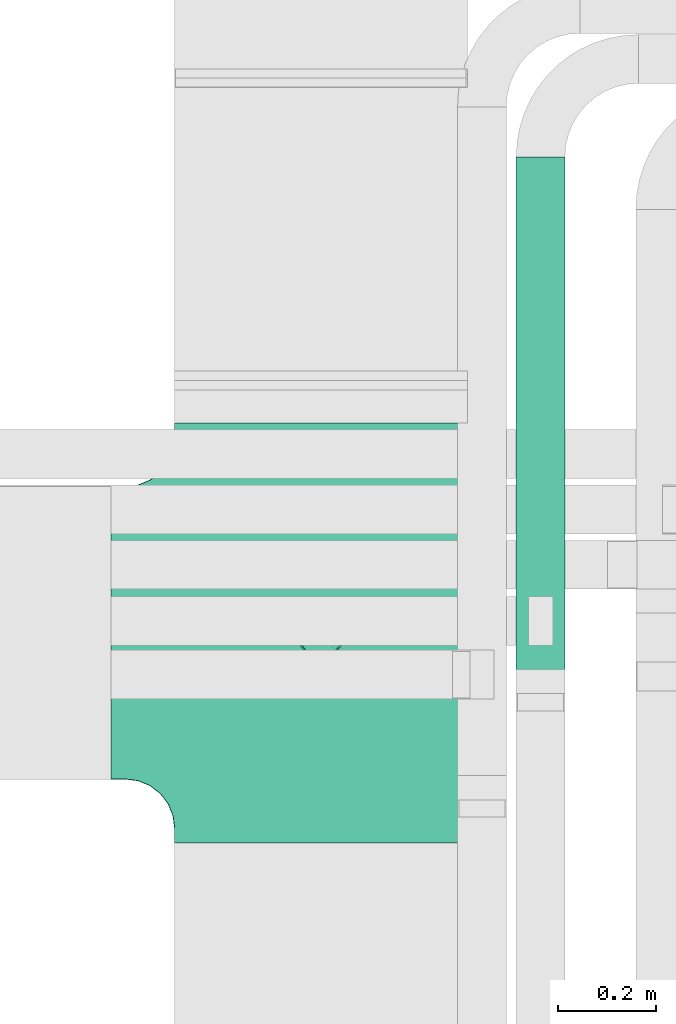
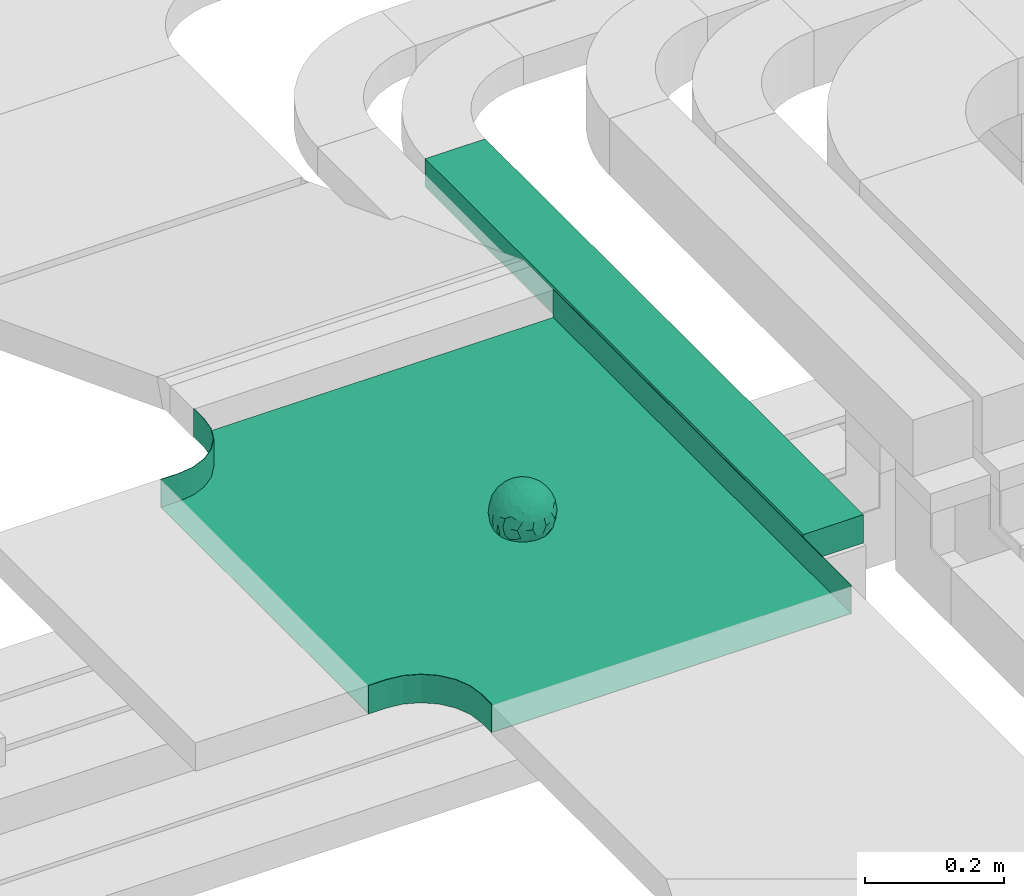
# One storey, part 2 of 38: 1 flow fitting, 1 flow segment.
"""IFC2X3 building model written with IfcOpenShell, lengths in millimetres."""

from ifc_helpers import new_model, entity, si_unit, converted_unit, derived_unit, direction, frame, origin, origin_2d_with_axis, place, context, subcontext, project, spatial, rectangle, extrude, faceted_brep, source, transform, mapped, material, material_list, type_object, type_shapes, element, save


model = new_model("IFC2X3")

# Units and contexts
model_context = context("Model", 3, precision=0.01, world=origin(), true_north=direction((6.12303176911189e-17, 1.0)))
body_context = subcontext(model_context, "Body", "Model", "MODEL_VIEW")
ifc_project = project(units=[si_unit("LENGTHUNIT", "METRE", prefix="MILLI"), si_unit("AREAUNIT", "SQUARE_METRE"), si_unit("VOLUMEUNIT", "CUBIC_METRE"), converted_unit("PLANEANGLEUNIT", "DEGREE", entity("IfcRatioMeasure", 0.0174532925199433), si_unit("PLANEANGLEUNIT", "RADIAN"), dimensions=[0, 0, 0, 0, 0, 0, 0]), si_unit("MASSUNIT", "GRAM", prefix="KILO"), derived_unit("MASSDENSITYUNIT", [(si_unit("MASSUNIT", "GRAM", prefix="KILO"), 1), (si_unit("LENGTHUNIT", "METRE"), -3)]), derived_unit("MOMENTOFINERTIAUNIT", [(si_unit("LENGTHUNIT", "METRE"), 4)]), si_unit("TIMEUNIT", "SECOND"), si_unit("FREQUENCYUNIT", "HERTZ"), si_unit("THERMODYNAMICTEMPERATUREUNIT", "DEGREE_CELSIUS"), derived_unit("THERMALTRANSMITTANCEUNIT", [(si_unit("MASSUNIT", "GRAM", prefix="KILO"), 1), (si_unit("THERMODYNAMICTEMPERATUREUNIT", "KELVIN"), -1), (si_unit("TIMEUNIT", "SECOND"), -3)]), derived_unit("VOLUMETRICFLOWRATEUNIT", [(si_unit("LENGTHUNIT", "METRE"), 3), (si_unit("TIMEUNIT", "SECOND"), -1)]), derived_unit("MASSFLOWRATEUNIT", [(si_unit("MASSUNIT", "GRAM", prefix="KILO"), 1), (si_unit("TIMEUNIT", "SECOND"), -1)]), derived_unit("ROTATIONALFREQUENCYUNIT", [(si_unit("TIMEUNIT", "SECOND"), -1)]), si_unit("ELECTRICCURRENTUNIT", "AMPERE"), si_unit("ELECTRICVOLTAGEUNIT", "VOLT"), si_unit("POWERUNIT", "WATT"), si_unit("FORCEUNIT", "NEWTON", prefix="KILO"), si_unit("ILLUMINANCEUNIT", "LUX"), si_unit("LUMINOUSFLUXUNIT", "LUMEN"), si_unit("LUMINOUSINTENSITYUNIT", "CANDELA"), derived_unit("USERDEFINED", [(si_unit("MASSUNIT", "GRAM", prefix="KILO"), -1), (si_unit("LENGTHUNIT", "METRE"), -2), (si_unit("TIMEUNIT", "SECOND"), 3), (si_unit("LUMINOUSFLUXUNIT", "LUMEN"), 1)]), derived_unit("LINEARVELOCITYUNIT", [(si_unit("LENGTHUNIT", "METRE"), 1), (si_unit("TIMEUNIT", "SECOND"), -1)]), si_unit("PRESSUREUNIT", "PASCAL"), derived_unit("USERDEFINED", [(si_unit("LENGTHUNIT", "METRE"), -2), (si_unit("MASSUNIT", "GRAM", prefix="KILO"), 1), (si_unit("TIMEUNIT", "SECOND"), -2)]), derived_unit("LINEARFORCEUNIT", [(si_unit("MASSUNIT", "GRAM", prefix="KILO"), 1), (si_unit("LENGTHUNIT", "METRE"), 1), (si_unit("TIMEUNIT", "SECOND"), -2), (si_unit("LENGTHUNIT", "METRE"), -1)]), derived_unit("PLANARFORCEUNIT", [(si_unit("MASSUNIT", "GRAM", prefix="KILO"), 1), (si_unit("LENGTHUNIT", "METRE"), 1), (si_unit("TIMEUNIT", "SECOND"), -2), (si_unit("LENGTHUNIT", "METRE"), -2)])], contexts=[model_context])

# Site, building, storey
site_placement = place(None, frame((0.0, -0.00077364408347762, 0.0)))
site = spatial("IfcSite", under=ifc_project, at=site_placement, CompositionType="ELEMENT")
building_placement = place(site_placement, origin())
building = spatial("IfcBuilding", under=site, at=building_placement, CompositionType="ELEMENT")
storey_placement = place(building_placement, frame((0.0, 0.0, 4200.0)))
storey = spatial("IfcBuildingStorey", under=building, at=storey_placement, CompositionType="ELEMENT", Elevation=4200.0)

# Flow segment
cable_carrier_segment_type = type_object("IfcCableCarrierSegmentType", PredefinedType="CABLETRAYSEGMENT")
flow_segment_placement = place(storey_placement, frame((10903.5911506353, 10608.7857236441, 2975.0)))
element("IfcFlowSegment", 1, at=flow_segment_placement, inside=storey, type_object=cable_carrier_segment_type, context=body_context, shape_type="SweptSolid", body=[
    extrude(rectangle(XDim=1091.74419399839, YDim=99.9999999999989, at=origin_2d_with_axis()), frame((50.0, 545.872096999197, 0.0), z_axis=(0.0, 0.0, 1.0), x_axis=(0.0, -1.0, 0.0)), (0.0, 0.0, 1.0), 49.9999999999995),
])

# Flow fitting
ifc_material_1 = material()
ifc_material_2 = material()
ifc_material_list = material_list([ifc_material_1, ifc_material_2])
cable_carrier_fitting_type = type_object("IfcCableCarrierFittingType", PredefinedType="NOTDEFINED", material=ifc_material_1)
shared_shape = source(origin(), body_context, "Body", "Brep", [
    faceted_brep([(43.65414201495, -13.6159823941412, -20.221792907194), (44.7734537304832, 0.0, -22.2561865791168), (48.2627667869764, -5.5982238187369, -11.8053052540677), (16.6591030416451, 5.32882774998004, -46.8409850521773), (11.5556000970565, -8.32997143460759, -47.9278591457525), (2.01883462715812, 2.6979389970297, -49.8863250993269), (-7.81264210311725, -35.946586740035, -33.8645171988286), (-17.2052206683237, -38.2719861359275, -27.1888848422606), (-11.1277274207927, -27.3202044092451, -40.3705352142543), (37.7030088371667, -7.24923843471304, -32.0301680723234), (10.6384317789277, 26.5155476513889, -41.0335168128579), (19.2127839264957, 19.8412508508062, -41.6796556903778), (10.4192511908907, 17.8098221318595, -45.5439286870577), (48.7463956090969, 0.0, 0.0), (48.0667721403428, 6.51594663441988, -12.1296271775358), (-37.4554170352858, 12.1627069007925, -30.8084451986326), (-31.3452178059555, 12.1462454498318, -37.0127821457472), (-38.0909108580228, 3.52194087904066, -32.1974912446565), (48.7463956090969, 11.1260466978072, 0.0), (9.66670567763161, 42.5651334019307, -24.3877883338551), (17.4761229293595, 37.974251726212, -27.4324868211278), (8.3452685270067, 35.3634447252368, -34.3479733081336), (36.7018152786982, 20.4309971840494, -27.121045505536), (28.2201055605836, 12.5803931374896, -39.3110588849404), (28.3969378462537, 24.0066360557188, -33.4259681422047), (37.1036906899333, 7.75177236926259, -32.6071489449891), (30.3928805396455, 38.1114667440203, 0.0), (34.7422273315263, 34.6429784184742, 0.0), (32.9402906787036, 32.1278050479557, -19.5637775698511), (26.0435337477646, 41.5799550695664, 0.0), (-44.7734518080776, 0.0, -22.2561904464559), (-35.9183276906112, -8.71634506105637, -33.6734177755349), (-42.698067512074, -12.1858404892465, -22.9865247983333), (5.42354673897514, -48.7621108487887, 0.0), (2.92058716488888e-07, -48.7843224693665, -10.9585528791684), (7.58713024513234, -47.4313421101439, -13.8817592643935), (33.995370401777, -31.6485911362954, -18.5116576873667), (40.0066375577234, -26.2448741379086, -14.5146661281262), (30.3928805396453, -38.1114667440373, 0.0), (-47.5540080368347, -8.6499737676748, -12.798213682019), (43.918984866252, -21.1502683953847, 0.0), (-47.5463631702337, 8.67950108284767, -12.8066236860544), (-43.9189848662407, 21.1502683953677, 0.0), (-41.5587306666804, 23.544384411141, -14.7828910593852), (-36.7018137075475, 20.43099797302, -27.1210470373429), (-42.6812093094125, 12.162707383776, -23.0300438771125), (-0.0435489182880873, -44.6798423199703, -22.4434799831651), (43.3459115209922, 13.125713179152, -21.1860238825719), (-9.67158541810518, -42.815796006327, -23.9430166822217), (2.9348104480415, -38.3026865671621, -32.0045479482528), (10.5768620896568, -32.3565839798164, -36.6221444141874), (17.476122931187, -37.9742517249799, -27.4324868216925), (29.4150529887209, -14.2918330913411, -37.8219270339311), (29.2594402117981, 0.0, -40.5448536622337), (-34.742227331515, 34.6429784184742, 0.0), (-35.5934709721032, 30.8679809236437, -16.7413433706631), (16.2706402169142, 46.2863325463322, 0.0), (15.3978227309257, 45.3692296018892, -14.301750259225), (10.8470934779447, 47.524221697552, 0.0), (-22.0930685137321, 42.2576087042555, -15.0396419586498), (-16.2706402169028, 46.2863325463322, 0.0), (-15.3976096147999, 45.3685960862683, -14.3039892096614), (-35.5741674477324, -30.877857614309, -16.7641438657341), (-34.7422273315149, -34.6429784184913, 0.0), (-41.544749127214, -23.5699215759022, -14.7814957586296), (-21.2012609977656, -29.9118129495041, -33.9969113035032), (-22.0930685137892, -42.2576087036302, -15.0396419603704), (-28.5890959469058, -35.7745555449591, -20.0709932115786), (27.967317375364, -26.9235432392394, -31.5111405422078), (26.5630985649032, -36.7540375314827, -21.0604491824418), (-4.69743067705244, -12.8233951627736, -48.0988012484001), (-3.71385705669819, -22.0483048804436, -44.7222485756373), (7.046128924104e-07, -29.8515321197025, -40.1109215813634), (-8.78090686085946, 23.4705297392872, -43.266960933916), (-10.7087237416586, 12.1533783795858, -47.3034737602475), (-19.1851128431225, 19.8122800241045, -41.7061746680507), (19.2127839279743, -19.841250849511, -41.6796556903208), (10.2736167511021, -43.2535488218696, -22.8819429499797), (-16.2706402169027, -46.2863325463492, 0.0), (-15.4179487650123, -45.4307793041134, -14.0830091848577), (-10.8470934779332, -47.524221697569, 0.0), (-21.6941869558721, -45.0484433951294, 0.0), (-26.043533747753, -41.5799550695834, 0.0), (-30.3928805396339, -38.1114667440373, 0.0), (-26.9077773704145, -11.7097120961444, -40.4827637348157), (-28.5735237959864, -22.531789977659, -34.2909926698312), (-14.3485559949731, 0.554718003800719, -47.8937493708156), (20.3912706461748, 29.6966950280778, -34.6742323035854), (25.8798715159051, 35.5620355309087, -23.7817972243053), (-1.90439589452332, 38.2956374757213, -32.090768557389), (-0.0435489197807358, 44.6798423204566, -22.4434799821603), (-9.54280395759116, 42.6678856642021, -24.2566779582937), (-10.1209262269152, 33.0365306692783, -36.140759450321), (-17.2052206685055, 38.2719861378047, -27.1888848394794), (-28.5890959468196, 35.7745555453602, -20.0709932109564), (-30.3928805396341, 38.1114667440203, 0.0), (-26.0435337477532, 41.5799550695664, 0.0), (-21.6941869558723, 45.0484433951125, 0.0), (0.920553890736952, 16.9936143333855, -47.0145685125519), (7.01705705346737e-07, 29.8515321215381, -40.1109215799846), (-28.4299335912282, 23.6392950735915, -33.6589156750601), (22.0754283900311, -42.7194435884069, -13.7012627481666), (0.0, -50.0, 0.0), (-7.98433520770671, 47.2879675743241, -14.1456181900809), (-10.8470934779333, 47.524221697552, 0.0), (-5.42354673896381, 48.7621108487718, 0.0), (-39.0915741233958, -31.1744900929452, 0.0), (-36.7018137083218, -20.4309979729983, -27.1210470363242), (-20.0503020227076, 29.8835350153312, -34.7125297808217), (48.7463956090969, -11.1260466978243, 0.0), (36.7018152787698, -20.430997183803, -27.1210455056374), (39.0915741234071, -31.1744900929452, 0.0), (43.9189848662521, 21.1502683953677, 0.0), (41.0372234357161, 24.481336168204, -14.7176924857918), (21.4315363761966, -9.86715979165204, -44.0831986838696), (19.8461085062156, -30.3026908878047, -34.4656191315041), (26.0435337477644, -41.5799550695834, 0.0), (8.27678352490751, -22.6176025005053, -43.8171075221857), (-19.1851128386707, -19.8122800229913, -41.7061746706354), (-17.559283921422, -9.66340012518247, -45.8070982074481), (-29.2594384269524, -1.64502744759432e-09, -40.5448549502702), (-22.2759109836818, 8.45458562997746, -43.957977338265), (21.6941869558835, -45.0484433951294, 0.0), (-7.7537430917927, -47.3248906716555, -14.1504131029038), (22.0929359888287, 42.3611643932195, -14.7456410726513), (21.6941869558837, 45.0484433951125, 0.0), (7.94480963874029, 47.2524194975214, -14.285966940796), (5.42354673897518, 48.7621108487718, 0.0), (-43.9189848662406, -21.1502683953848, 0.0), (-39.0915741233959, 31.1744900929281, 0.0), (-48.7463956090855, 11.1260466978072, 0.0), (-48.7463956090855, -11.1260466978243, 0.0), (-48.7463956090855, 0.0, 0.0), (0.0, 50.0, 0.0), (2.95674852821199e-07, 48.76542105366, -11.0423597776141), (-5.42354673896377, -48.7621108487887, 0.0), (16.2706402169141, -46.2863325463492, 0.0), (10.8470934779446, -47.524221697569, 0.0), (39.0915741234072, 31.1744900929281, 0.0), (34.7422273315262, -34.6429784184913, 0.0), (-43.6541417785539, -13.6159824952714, 20.2217933494142), (-44.7734534735007, 0.0, 22.2561870960884), (-48.2627667188257, -5.59822380837423, 11.8053055375658), (-16.6591016552529, 5.32882757852047, 46.8409855647676), (-11.5555985538933, -8.32997141356845, 47.9278595214841), (-2.01883285210585, 2.69793886619285, 49.8863251782511), (7.81264298940045, -35.9465866899564, 33.8645170475355), (17.2052219498432, -38.2719853643866, 27.1888851173795), (11.1277291939633, -27.3202042660781, 40.370534822402), (-37.7030082707847, -7.24923849358482, 32.0301687256941), (-10.6384306361632, 26.5155474098453, 41.0335172652288), (-19.2127828542464, 19.8412506695278, 41.6796562709507), (-10.419249902145, 17.8098220464058, 45.5439290153173), (-48.0667720467311, 6.51594672713361, 12.1296274986609), (37.4554198551597, 12.1627053911885, 30.8084423663635), (31.3452204336626, 12.1462444514283, 37.0127802480704), (38.0909129847824, 3.52193921618223, 32.1974889105362), (-9.66670492251031, 42.565133342123, 24.3877887375616), (-17.4761222809685, 37.9742516795029, 27.4324872988574), (-8.34526747232003, 35.3634445391436, 34.3479737559899), (-36.7018147879525, 20.4309972885889, 27.1210460908894), (-28.2201045883605, 12.5803929822385, 39.3110596325575), (-28.3969371324566, 24.0066357536882, 33.4259689655335), (-37.1036900366786, 7.75177247673037, 32.6071496627812), (-32.9402901163369, 32.1278052689131, 19.5637781538672), (44.773453728735, 0.0, 22.2561865826485), (35.9183286182219, -8.71634518545332, 33.6734167539099), (42.6980684782056, -12.1858381773451, 22.9865242293622), (-5.1564557811304e-08, -48.7843224155168, 10.9585531189064), (-7.58712982046247, -47.4313421866568, 13.8817592350767), (-33.9953700157816, -31.6485912778883, 18.5116581541388), (-40.0066373233245, -26.2448743223541, 14.5146664406737), (47.5540088657557, -8.64997340643016, 12.7982108462298), (47.5463641063755, 8.67950029611492, 12.8066207437518), (41.5587323717035, 23.5443822102692, 14.7828897714275), (36.7018153946169, 20.4309968399072, 27.121045607934), (42.6812105193328, 12.1627054070682, 23.0300426787683), (0.0435498934198039, -44.6798421141237, 22.4434803910813), (-43.3459112327239, 13.1257132261269, 21.1860244432478), (9.6715868653752, -42.8157959611257, 23.9430161784588), (-2.93481023367521, -38.3026862522726, 32.0045483447802), (-10.5768615382775, -32.3565831315815, 36.6221453228799), (-17.4761222811971, -37.9742516793303, 27.4324872989742), (-29.4150522011614, -14.2918331221065, 37.8219276348162), (-29.259439267976, 0.0, 40.5448543433553), (35.593472529025, 30.867979902287, 16.7413419437535), (-15.3978225621776, 45.3692295068837, 14.3017507422931), (22.0930688164668, 42.2576085856364, 15.0396418472572), (15.3976099169387, 45.3685960801975, 14.3039889037045), (35.5741692798952, -30.8778564526781, 16.7641421174582), (41.5447510295928, -23.5699190140567, 14.7814944968718), (21.2012629219892, -29.9118119699372, 33.9969109653959), (22.0930688164889, -42.2576085855628, 15.039641847479), (28.5890966709526, -35.7745557157875, 20.0709918757936), (-27.9673166448933, -26.9235432178776, 31.5111412087844), (-26.5630981091642, -36.7540374223405, 21.0604499477277), (4.69743244094294, -12.8233948182002, 48.0988011680158), (3.71385918047916, -22.0483045188225, 44.7222485775695), (6.0892732202368e-07, -29.8515316280668, 40.1109219472655), (8.78090833347225, 23.4705290601204, 43.2669610034903), (10.7087255323208, 12.1533779204354, 47.3034734728551), (19.1851144535653, 19.8122792782791, 41.7061742815566), (-19.212782854423, -19.8412506693283, 41.6796562709723), (-10.2736163541564, -43.2535491498667, 22.8819425082012), (15.4179491053271, -45.430779442795, 14.0830083649343), (26.9077783310918, -11.7097109554472, 40.4827634262511), (28.5735255699879, -22.531788297607, 34.2909922955619), (14.3485579041194, 0.554717908736034, 47.893748799971), (-20.3912698186306, 29.6966949125693, 34.674232889184), (-25.8798708903081, 35.5620354347035, 23.7817980489561), (1.90439718168615, 38.2956370656312, 32.0907689704016), (0.0435498935700709, 44.6798421141929, 22.4434803909095), (9.54280511870019, 42.6678852802435, 24.2566781769111), (10.1209277017953, 33.036529901429, 36.1407597392074), (17.2052219497738, 38.2719853646937, 27.1888851169673), (28.5890966709116, 35.7745557157488, 20.0709918758907), (-0.920552500958269, 16.993613961591, 47.0145686741652), (6.09264554473049e-07, 29.8515316283504, 40.1109219470418), (28.4299352793349, 23.6392936643312, 33.6589152389788), (-22.0754282965694, -42.7194435788052, 13.7012629286858), (7.9843354212563, 47.2879674404261, 14.1456185171795), (36.7018153946056, -20.4309968401043, 27.1210456078136), (20.0503035663584, 29.8835340747136, 34.7125296989797), (-36.7018147879654, -20.4309972885437, 27.1210460909186), (-41.0372232425556, 24.4813362747081, 14.7176928472045), (-21.4315352776288, -9.8671595900376, 44.0831992630873), (-19.8461080318002, -30.3026912052829, 34.4656191255603), (-8.27678185920825, -22.617601585775, 43.8171083090061), (19.1851144530605, -19.8122792780652, 41.7061742818985), (17.5592847966676, -9.6634000411993, 45.8070978896755), (29.259440221343, 0.0, 40.5448536553604), (22.2759127990671, 8.45458631346954, 43.9579762868721), (7.75374356219277, -47.3248906381916, 14.1504129570858), (-22.0929358819219, 42.3611643749655, 14.7456412852645), (-7.94480944914509, 47.2524194744515, 14.2859671225497), (-5.23333520595152e-08, 48.7654210084985, 11.0423599770715)], [[[0, 1, 2]], [[3, 4, 5]], [[6, 7, 8]], [[1, 0, 9]], [[10, 11, 12]], [[13, 2, 14]], [[15, 16, 17]], [[14, 18, 13]], [[19, 20, 21]], [[22, 23, 24]], [[1, 9, 25]], [[26, 27, 28, 29]], [[30, 31, 32]], [[33, 34, 35]], [[36, 37, 38]], [[32, 39, 30]], [[2, 40, 0]], [[23, 22, 25]], [[41, 42, 43]], [[44, 15, 45]], [[46, 35, 34]], [[25, 22, 47]], [[31, 30, 17]], [[48, 49, 46]], [[50, 51, 49]], [[52, 53, 9]], [[43, 54, 55]], [[56, 57, 58]], [[59, 60, 61]], [[62, 63, 64]], [[8, 7, 65]], [[7, 66, 67]], [[68, 36, 69]], [[70, 5, 4]], [[8, 71, 72]], [[73, 74, 75]], [[68, 76, 52]], [[77, 46, 49]], [[78, 79, 80]], [[7, 6, 48]], [[67, 81, 82, 83]], [[84, 85, 31]], [[85, 65, 67]], [[70, 86, 5]], [[23, 3, 11]], [[21, 87, 10]], [[21, 20, 87]], [[28, 24, 88]], [[19, 89, 90]], [[91, 90, 89]], [[91, 92, 93]], [[94, 95, 96, 97]], [[98, 99, 10]], [[100, 16, 44]], [[77, 51, 101]], [[33, 102, 34]], [[103, 91, 61]], [[93, 59, 61]], [[104, 105, 103]], [[106, 64, 63]], [[107, 31, 85]], [[100, 94, 108]], [[108, 93, 92]], [[43, 55, 44]], [[0, 40, 37]], [[2, 13, 109]], [[2, 1, 14]], [[110, 9, 0]], [[2, 109, 40]], [[37, 40, 111]], [[47, 14, 1]], [[112, 14, 47]], [[113, 112, 47]], [[112, 18, 14]], [[47, 22, 113]], [[52, 9, 110]], [[53, 25, 9]], [[25, 47, 1]], [[23, 25, 53]], [[68, 52, 110]], [[76, 4, 114]], [[51, 115, 69]], [[50, 115, 51]], [[110, 36, 68]], [[3, 23, 53]], [[23, 11, 24]], [[52, 76, 114]], [[98, 12, 5]], [[11, 87, 24]], [[24, 28, 22]], [[87, 88, 24]], [[36, 116, 69]], [[28, 27, 113]], [[114, 3, 53]], [[76, 115, 117]], [[70, 4, 117]], [[118, 84, 119]], [[119, 70, 118]], [[120, 16, 121]], [[37, 36, 110]], [[116, 36, 38]], [[116, 122, 69]], [[34, 123, 46]], [[10, 87, 11]], [[87, 20, 88]], [[12, 98, 10]], [[10, 99, 21]], [[74, 5, 86]], [[73, 75, 108]], [[124, 56, 125]], [[124, 29, 88]], [[89, 21, 99]], [[21, 89, 19]], [[92, 89, 99]], [[89, 92, 91]], [[126, 127, 58]], [[88, 29, 28]], [[20, 57, 124]], [[88, 20, 124]], [[57, 20, 19]], [[73, 92, 99]], [[92, 73, 108]], [[99, 98, 73]], [[74, 86, 121]], [[73, 98, 74]], [[5, 74, 98]], [[100, 108, 75]], [[94, 93, 108]], [[86, 120, 121]], [[100, 44, 55]], [[75, 16, 100]], [[17, 16, 120]], [[31, 17, 120]], [[17, 30, 45]], [[84, 31, 120]], [[31, 107, 32]], [[41, 45, 30]], [[43, 44, 45]], [[107, 64, 32]], [[39, 64, 128]], [[30, 39, 41]], [[129, 43, 42]], [[41, 130, 42]], [[43, 45, 41]], [[62, 83, 63]], [[95, 94, 55]], [[100, 55, 94]], [[64, 107, 62]], [[131, 39, 128]], [[64, 106, 128]], [[85, 62, 107]], [[67, 83, 62]], [[39, 32, 64]], [[130, 41, 132]], [[59, 97, 60]], [[133, 127, 134]], [[59, 94, 97]], [[104, 61, 60]], [[94, 59, 93]], [[126, 134, 127]], [[126, 58, 57]], [[19, 90, 126]], [[134, 105, 133]], [[126, 90, 134]], [[103, 90, 91]], [[105, 134, 103]], [[90, 103, 134]], [[119, 120, 86]], [[84, 118, 85]], [[65, 85, 118]], [[62, 85, 67]], [[8, 65, 118]], [[67, 65, 7]], [[71, 118, 70]], [[8, 72, 6]], [[49, 6, 72]], [[6, 49, 48]], [[50, 49, 72]], [[77, 49, 51]], [[101, 69, 122]], [[123, 34, 135]], [[101, 122, 136]], [[137, 77, 136]], [[78, 81, 66]], [[7, 79, 66]], [[67, 66, 81]], [[79, 7, 48]], [[35, 137, 33]], [[123, 80, 79]], [[135, 34, 102]], [[35, 46, 77]], [[80, 123, 135]], [[46, 123, 48]], [[117, 50, 72]], [[115, 76, 68]], [[117, 72, 71]], [[4, 76, 117]], [[39, 132, 41]], [[39, 131, 132]], [[137, 35, 77]], [[124, 57, 56]], [[126, 57, 19]], [[103, 61, 104]], [[61, 91, 93]], [[77, 101, 136]], [[51, 69, 101]], [[28, 113, 22]], [[112, 113, 138]], [[16, 75, 121]], [[74, 121, 75]], [[66, 79, 78]], [[123, 79, 48]], [[0, 37, 110]], [[37, 111, 139, 38]], [[29, 124, 125]], [[115, 50, 117]], [[69, 115, 68]], [[120, 119, 84]], [[70, 119, 86]], [[11, 3, 12]], [[5, 12, 3]], [[118, 71, 8]], [[117, 71, 70]], [[3, 114, 4]], [[53, 52, 114]], [[27, 138, 113]], [[45, 15, 17]], [[44, 16, 15]], [[55, 54, 95]], [[43, 129, 54]], [[140, 141, 142]], [[143, 144, 145]], [[146, 147, 148]], [[141, 140, 149]], [[150, 151, 152]], [[132, 142, 153]], [[154, 155, 156]], [[153, 130, 132]], [[157, 158, 159]], [[160, 161, 162]], [[141, 149, 163]], [[95, 54, 164, 96]], [[165, 166, 167]], [[135, 168, 169]], [[170, 171, 83]], [[167, 172, 165]], [[142, 141, 153]], [[161, 160, 163]], [[173, 112, 174]], [[175, 154, 176]], [[177, 169, 168]], [[163, 160, 178]], [[166, 165, 156]], [[179, 180, 177]], [[181, 182, 180]], [[183, 184, 149]], [[174, 27, 185]], [[60, 186, 104]], [[187, 56, 188]], [[189, 139, 190]], [[148, 147, 191]], [[147, 192, 193]], [[194, 170, 195]], [[196, 145, 144]], [[148, 197, 198]], [[199, 200, 201]], [[194, 202, 183]], [[203, 177, 180]], [[136, 204, 137]], [[147, 146, 179]], [[193, 122, 116, 38]], [[205, 206, 166]], [[206, 191, 193]], [[196, 207, 145]], [[161, 143, 151]], [[159, 208, 150]], [[159, 158, 208]], [[164, 162, 209]], [[157, 210, 211]], [[212, 211, 210]], [[212, 213, 214]], [[215, 26, 29, 125]], [[216, 217, 150]], [[218, 155, 175]], [[203, 182, 219]], [[135, 102, 168]], [[220, 212, 188]], [[214, 187, 188]], [[58, 127, 220]], [[111, 190, 139]], [[221, 166, 206]], [[218, 215, 222]], [[222, 214, 213]], [[174, 185, 175]], [[171, 140, 128]], [[132, 131, 142]], [[142, 128, 140]], [[223, 149, 140]], [[142, 131, 128]], [[171, 128, 106]], [[178, 153, 141]], [[42, 153, 178]], [[224, 42, 178]], [[42, 130, 153]], [[178, 160, 224]], [[183, 149, 223]], [[184, 163, 149]], [[163, 178, 141]], [[161, 163, 184]], [[194, 183, 223]], [[202, 144, 225]], [[182, 226, 195]], [[181, 226, 182]], [[223, 170, 194]], [[143, 161, 184]], [[161, 151, 162]], [[183, 202, 225]], [[216, 152, 145]], [[151, 208, 162]], [[162, 164, 160]], [[208, 209, 162]], [[170, 82, 195]], [[164, 54, 224]], [[225, 143, 184]], [[202, 226, 227]], [[196, 144, 227]], [[228, 205, 229]], [[229, 196, 228]], [[230, 155, 231]], [[171, 170, 223]], [[82, 170, 83]], [[82, 81, 195]], [[168, 232, 177]], [[150, 208, 151]], [[208, 158, 209]], [[152, 216, 150]], [[150, 217, 159]], [[200, 145, 207]], [[199, 201, 222]], [[233, 60, 97]], [[233, 96, 209]], [[210, 159, 217]], [[159, 210, 157]], [[213, 210, 217]], [[210, 213, 212]], [[234, 105, 104]], [[209, 96, 164]], [[158, 186, 233]], [[209, 158, 233]], [[186, 158, 157]], [[199, 213, 217]], [[213, 199, 222]], [[217, 216, 199]], [[200, 207, 231]], [[199, 216, 200]], [[145, 200, 216]], [[218, 222, 201]], [[215, 214, 222]], [[207, 230, 231]], [[218, 175, 185]], [[201, 155, 218]], [[156, 155, 230]], [[166, 156, 230]], [[156, 165, 176]], [[205, 166, 230]], [[166, 221, 167]], [[173, 176, 165]], [[174, 175, 176]], [[221, 190, 167]], [[172, 190, 40]], [[165, 172, 173]], [[138, 174, 112]], [[173, 18, 112]], [[174, 176, 173]], [[189, 38, 139]], [[26, 215, 185]], [[218, 185, 215]], [[190, 221, 189]], [[109, 172, 40]], [[190, 111, 40]], [[206, 189, 221]], [[193, 38, 189]], [[172, 167, 190]], [[18, 173, 13]], [[187, 125, 56]], [[133, 105, 235]], [[187, 215, 125]], [[58, 188, 56]], [[215, 187, 214]], [[234, 235, 105]], [[234, 104, 186]], [[157, 211, 234]], [[235, 127, 133]], [[234, 211, 235]], [[220, 211, 212]], [[127, 235, 220]], [[211, 220, 235]], [[229, 230, 207]], [[205, 228, 206]], [[191, 206, 228]], [[189, 206, 193]], [[148, 191, 228]], [[193, 191, 147]], [[197, 228, 196]], [[148, 198, 146]], [[180, 146, 198]], [[146, 180, 179]], [[181, 180, 198]], [[203, 180, 182]], [[219, 195, 81]], [[232, 168, 33]], [[219, 81, 78]], [[80, 203, 78]], [[136, 122, 192]], [[147, 204, 192]], [[193, 192, 122]], [[204, 147, 179]], [[169, 80, 135]], [[232, 137, 204]], [[33, 168, 102]], [[169, 177, 203]], [[137, 232, 33]], [[177, 232, 179]], [[227, 181, 198]], [[226, 202, 194]], [[227, 198, 197]], [[144, 202, 227]], [[172, 13, 173]], [[172, 109, 13]], [[80, 169, 203]], [[233, 186, 60]], [[234, 186, 157]], [[220, 188, 58]], [[188, 212, 214]], [[203, 219, 78]], [[182, 195, 219]], [[164, 224, 160]], [[42, 224, 129]], [[155, 201, 231]], [[200, 231, 201]], [[192, 204, 136]], [[232, 204, 179]], [[140, 171, 223]], [[171, 106, 63, 83]], [[96, 233, 97]], [[226, 181, 227]], [[195, 226, 194]], [[230, 229, 205]], [[196, 229, 207]], [[151, 143, 152]], [[145, 152, 143]], [[228, 197, 148]], [[227, 197, 196]], [[143, 225, 144]], [[184, 183, 225]], [[54, 129, 224]], [[176, 154, 156]], [[175, 155, 154]], [[185, 27, 26]], [[174, 138, 27]]]),
    faceted_brep([(-303.407417371086, -374.118095489752, 25.0), (-300.0, -400.0, 25.0), (-300.0, -430.0, 25.0), (-299.199999999993, -430.0, 25.0), (-299.199999999993, -400.0, 25.0), (-302.634676710055, -373.911040253671, 25.0), (-312.704639298522, -349.600000000004, 25.0), (-328.72363645639, -328.723636456399, 25.0), (-349.599999999995, -312.704639298532, 25.0), (-373.911040253662, -302.634676710065, 25.0), (-400.0, -299.200000000004, 25.0), (-430.0, -299.200000000004, 25.0), (-430.0, -300.0, 25.0), (-400.0, -300.0, 25.0), (-374.118095489745, -303.407417371099, 25.0), (-350.0, -313.397459621561, 25.0), (-329.28932188134, -329.289321881349, 25.0), (-313.39745962155, -350.0, 25.0), (430.0, -300.0, 25.0), (430.0, -299.200000000004, 25.0), (400.0, -299.200000000004, 25.0), (373.911040253717, -302.634676710066, 25.0), (349.600000000045, -312.704639298531, 25.0), (328.723636456434, -328.723636456398, 25.0), (312.704639298558, -349.600000000001, 25.0), (302.634676710081, -373.911040253668, 25.0), (299.200000000007, -400.0, 25.0), (299.200000000007, -430.0, 25.0), (300.0, -430.0, 25.0), (300.0, -400.0, 25.0), (303.407417371113, -374.11809548975, 25.0), (313.397459621587, -350.0, 25.0), (329.289321881385, -329.289321881348, 25.0), (350.0, -313.397459621561, 25.0), (374.1180954898, -303.4074173711, 25.0), (400.0, -300.0, 25.0), (430.0, 299.199999999995, 25.0), (430.0, 300.0, 25.0), (-430.0, 300.0, 25.0), (-430.0, 299.199999999995, 25.0), (-430.0, -300.0, -25.0), (-430.0, 300.0, -25.0), (430.0, 300.0, -25.0), (430.0, -300.0, -25.0), (400.0, -300.0, -25.0), (374.1180954898, -303.4074173711, -25.0), (350.0, -313.397459621561, -25.0), (329.289321881385, -329.289321881348, -25.0), (313.397459621587, -350.0, -25.0), (303.407417371113, -374.11809548975, -25.0), (300.0, -400.0, -25.0), (300.0, -430.0, -25.0), (-300.0, -430.0, -25.0), (-300.0, -400.0, -25.0), (-303.407417371086, -374.118095489752, -25.0), (-313.39745962155, -350.0, -25.0), (-329.28932188134, -329.289321881349, -25.0), (-350.0, -313.397459621561, -25.0), (-374.118095489745, -303.407417371099, -25.0), (-400.0, -300.0, -25.0), (-300.0, -400.0, -24.199999999986), (299.200000000007, -430.0, -24.199999999986), (-299.199999999993, -430.0, -24.199999999986), (-299.199999999993, -400.0, -24.199999999986), (-400.0, -299.200000000004, -24.199999999986), (-430.0, -299.200000000004, -24.199999999986), (430.0, -299.200000000004, -24.199999999986), (400.0, -299.200000000004, -24.199999999986), (-430.0, 299.199999999995, -24.199999999986), (-400.0, -300.0, -24.199999999986), (400.0, -300.0, -24.199999999986), (430.0, 299.199999999995, -24.199999999986), (299.200000000007, -400.0, -24.199999999986), (300.0, -400.0, -24.199999999986), (-373.911040253662, -302.634676710065, -24.199999999986), (-349.599999999995, -312.704639298532, -24.199999999986), (-328.72363645639, -328.7236364564, -24.199999999986), (-312.704639298522, -349.600000000004, -24.199999999986), (-302.634676710055, -373.911040253671, -24.199999999986), (302.634676710081, -373.911040253668, -24.199999999986), (312.704639298557, -349.600000000001, -24.199999999986), (328.723636456434, -328.723636456398, -24.199999999986), (349.600000000044, -312.704639298532, -24.199999999986), (373.911040253716, -302.634676710066, -24.199999999986)], [[[0, 1, 2, 3, 4, 5, 6, 7, 8, 9, 10, 11, 12, 13, 14, 15, 16, 17]], [[18, 19, 20, 21, 22, 23, 24, 25, 26, 27, 28, 29, 30, 31, 32, 33, 34, 35]], [[36, 37, 38, 39]], [[40, 41, 42, 43, 44, 45, 46, 47, 48, 49, 50, 51, 52, 53, 54, 55, 56, 57, 58, 59]], [[2, 1, 60, 53, 52]], [[3, 2, 52, 51, 28, 27, 61, 62]], [[4, 3, 62, 63]], [[11, 10, 64, 65]], [[20, 19, 66, 67]], [[39, 38, 41, 40, 12, 11, 65, 68]], [[13, 12, 40, 59, 69]], [[18, 35, 70, 44, 43]], [[19, 18, 43, 42, 37, 36, 71, 66]], [[27, 26, 72, 61]], [[29, 28, 51, 50, 73]], [[38, 37, 42, 41]], [[36, 39, 68, 71]], [[68, 65, 64, 74, 75, 76, 77, 78, 63, 62, 61, 72, 79, 80, 81, 82, 83, 67, 66, 71]], [[14, 13, 69, 59, 58]], [[58, 57, 15, 14]], [[15, 57, 56, 16]], [[0, 17, 55, 54]], [[0, 54, 53, 60, 1]], [[55, 17, 16, 56]], [[5, 4, 63, 78]], [[6, 5, 78, 77]], [[7, 6, 77, 76]], [[8, 7, 76, 75]], [[9, 8, 75, 74]], [[10, 9, 74, 64]], [[21, 20, 67, 83]], [[22, 21, 83, 82]], [[23, 22, 82, 81]], [[81, 80, 24, 23]], [[24, 80, 79, 25]], [[79, 72, 26, 25]], [[30, 29, 73, 50, 49]], [[31, 30, 49, 48]], [[31, 48, 47, 32]], [[33, 32, 47, 46]], [[45, 34, 33, 46]], [[34, 45, 44, 70, 35]]]),
])
type_shapes(cable_carrier_fitting_type, [shared_shape])
flow_fitting_placement = place(storey_placement, frame((10503.5911506354, 10726.3498749112, 3135.0), z_axis=(0.0, 0.0, 1.0), x_axis=(0.0, -1.0, 0.0)))
element("IfcFlowFitting", 2, at=flow_fitting_placement, inside=storey, type_object=cable_carrier_fitting_type, material=ifc_material_list, Name="470_DKC_S5_T", context=body_context, shape_type="MappedRepresentation", body=[
    mapped(shared_shape, transform((0.0, 0.0, 0.0), scale=1.0)),
])

save(model, "model.ifc")
